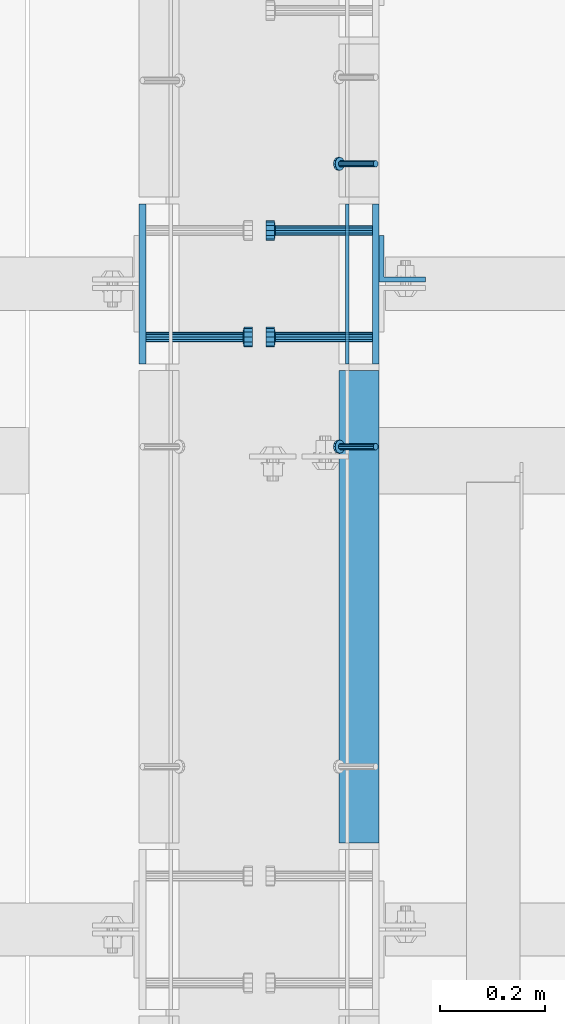
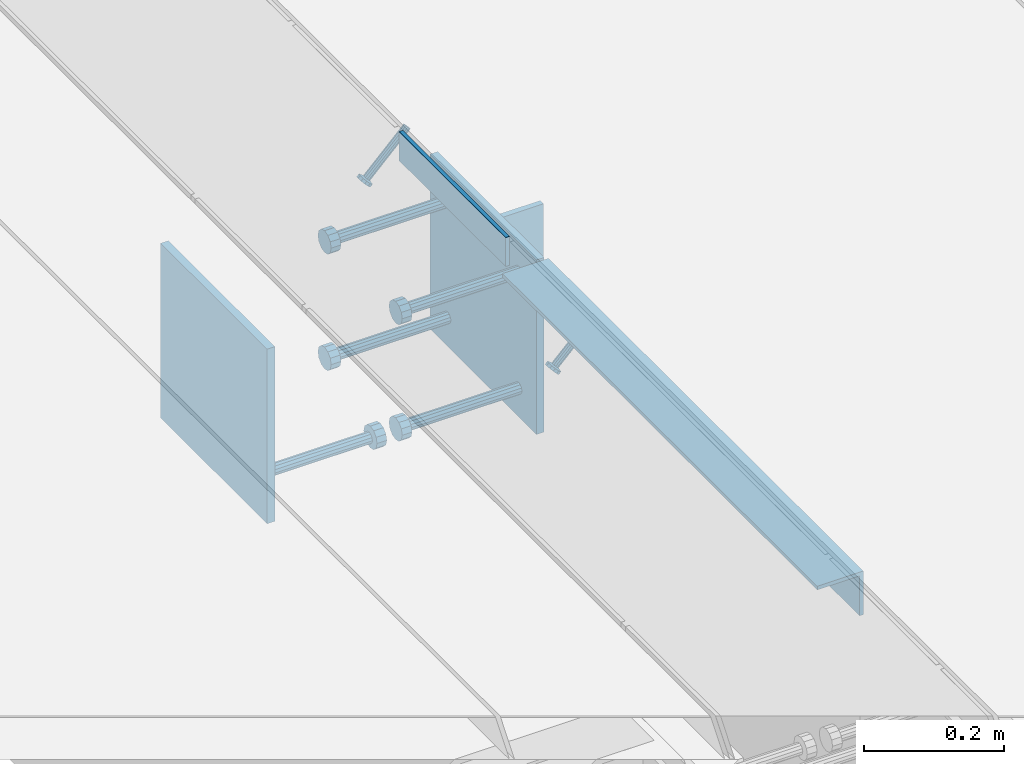
# One storey, part 2148 of 3843: 10 beams, 2 members, 5 elements without a shape of their own.
"""IFC2X3 building model written with IfcOpenShell, lengths in millimetres."""

from ifc_helpers import new_model, si_unit, frame, origin_with_axes, place, context, subcontext, project, spatial, faceted_brep, material, type_object, element, aggregate, save


model = new_model("IFC2X3")

# Units and contexts
model_context = context("Model", 3, precision=1e-05, world=origin_with_axes())
body_context = subcontext(model_context, "Body", "Model", "MODEL_VIEW")
ifc_project = project(units=[si_unit("LENGTHUNIT", "METRE", prefix="MILLI"), si_unit("AREAUNIT", "SQUARE_METRE"), si_unit("VOLUMEUNIT", "CUBIC_METRE"), si_unit("MASSUNIT", "GRAM", prefix="KILO"), si_unit("TIMEUNIT", "SECOND"), si_unit("PLANEANGLEUNIT", "RADIAN"), si_unit("SOLIDANGLEUNIT", "STERADIAN"), si_unit("THERMODYNAMICTEMPERATUREUNIT", "DEGREE_CELSIUS"), si_unit("LUMINOUSINTENSITYUNIT", "LUMEN")], contexts=[model_context])

# Site, building, storey
site_placement = place(None, origin_with_axes())
site = spatial("IfcSite", under=ifc_project, at=site_placement, CompositionType="ELEMENT")
building_placement = place(site_placement, origin_with_axes())
building = spatial("IfcBuilding", under=site, at=building_placement, Name="Undefined", CompositionType="ELEMENT")
storey_placement = place(building_placement, origin_with_axes())
storey = spatial("IfcBuildingStorey", under=building, at=storey_placement, Name="Undefined", CompositionType="ELEMENT", Elevation=0.0)

# Assembly, beam
assembly_1_placement = place(storey_placement, origin_with_axes())
assembly_1 = element("IfcElementAssembly", 1, at=assembly_1_placement, inside=storey, Name="EMBED PLATE", AssemblyPlace="NOTDEFINED", PredefinedType="RIGID_FRAME")
ifc_material_1 = material(Name="STEEL/A36")
beam_type_1 = type_object("IfcBeamType", PredefinedType="NOTDEFINED")
beam_1_placement = place(assembly_1_placement, frame((62728.4750030518, 17306.925, 30454.6), z_axis=(0.0, 0.0, 1.0), x_axis=(0.0, 1.0, 0.0)))
beam_1 = element("IfcBeam", 2, at=beam_1_placement, type_object=beam_type_1, material=ifc_material_1, Name="PLATE", context=body_context, shape_type="Brep", body=[
    faceted_brep([(0.0, 3.17499999999927, -25.4000000000015), (0.0, 3.17499999999927, 25.4000000000015), (304.800000000003, 3.17500000000291, 25.4000000000015), (304.800000000003, 3.17500000000291, -25.4000000000015), (0.0, -3.17499999999927, 25.4000000000015), (304.800000000003, -3.17500000000291, 25.4000000000015), (0.0, -3.17499999999927, -25.4000000000015), (304.800000000003, -3.17500000000291, -25.4000000000015)], [[[0, 1, 2, 3]], [[1, 4, 5, 2]], [[4, 6, 7, 5]], [[6, 0, 3, 7]], [[5, 7, 3, 2]], [[6, 4, 1, 0]]]),
])

# Assembly, member
assembly_2_placement = place(storey_placement, origin_with_axes())
assembly_2 = element("IfcElementAssembly", 3, at=assembly_2_placement, inside=storey, Name="ANGLE", AssemblyPlace="NOTDEFINED", PredefinedType="RIGID_FRAME")
ifc_material_2 = material(Name="STEEL/A108")
member_type = type_object("IfcMemberType", PredefinedType="NOTDEFINED")
member_1_placement = place(assembly_2_placement, frame((62782.4499976766, 17687.9250728612, 30422.8500045777), z_axis=(0.0, -1.0, 0.0), x_axis=(-0.707106781186548, 0.0, -0.707106781186548)))
member_1 = element("IfcMember", 4, at=member_1_placement, type_object=member_type, material=ifc_material_2, Name="HEADED STUD ANCHOR", context=body_context, shape_type="Brep", body=[
    faceted_brep([(7.27595761418343e-12, -3.18000006675175, 5.5), (0.0, -5.49999999998363, 3.1800000667572), (94.4879985803855, -5.50000000011278, 3.1800000667572), (94.4879985803782, -3.18000006687362, 5.5), (0.0, -6.3499999046162, 0.0), (94.4879985803855, -6.34999990474535, 0.0), (0.0, -5.49999999998363, -3.1800000667572), (94.4879985803855, -5.50000000011278, -3.1800000667572), (7.27595761418343e-12, -3.18000006675175, -5.5), (94.4879985803782, -3.18000006687362, -5.5), (7.27595761418343e-12, -1.81898940354586e-12, -6.34999990463257), (94.4879985803782, -1.20053300634027e-10, -6.34999990463257), (0.0, 3.18000006675175, -5.5), (94.4879985803709, 3.18000006663351, -5.5), (7.27595761418343e-12, 5.49999999998363, -3.1800000667572), (94.4879985803709, 5.49999999987267, -3.1800000667572), (7.27595761418343e-12, 6.3499999046162, 0.0), (94.4879985803673, 6.34999990450706, 0.0), (7.27595761418343e-12, 5.49999999998363, 3.1800000667572), (94.4879985803709, 5.49999999987267, 3.1800000667572), (0.0, 3.18000006675175, 5.5), (94.4879985803709, 3.18000006663351, 5.5), (7.27595761418343e-12, -1.81898940354586e-12, 6.34999990463257), (94.4879985803782, -1.20053300634027e-10, 6.34999990463257), (96.5199985498621, -10.9899997712273, 6.34999990463257), (96.5199985498548, -6.34000015270249, 10.9899997711182), (96.5199985498621, -12.6999998093743, 0.0), (96.5199985498621, -10.9899997712273, -6.34999990463257), (96.5199985498548, -6.34000015270249, -10.9899997711182), (96.5199985498475, -1.21872290037572e-10, -12.6899995803833), (96.5199985498402, 6.34000015245874, -10.9899997711182), (96.519998549833, 10.9899997709817, -6.34999990463257), (96.519998549833, 12.6999998091305, 0.0), (96.519998549833, 10.9899997709817, 6.34999990463257), (96.5199985498402, 6.34000015245874, 10.9899997711182), (96.5199985498475, -1.21872290037572e-10, 12.6899995803833), (101.599998473539, -10.9899997712328, 6.34999990463257), (101.599998473532, -6.34000015270976, 10.9899997711182), (101.599998473539, -12.6999998093797, 0.0), (101.599998473539, -10.9899997712328, -6.34999990463257), (101.599998473532, -6.34000015270976, -10.9899997711182), (101.599998473524, -1.29148247651756e-10, -12.6899995803833), (101.599998473517, 6.34000015245329, -10.9899997711182), (101.59999847351, 10.9899997709763, -6.34999990463257), (101.599998473503, 12.6999998091196, 0.0), (101.59999847351, 10.9899997709763, 6.34999990463257), (101.599998473517, 6.34000015245329, 10.9899997711182), (101.599998473524, -1.29148247651756e-10, 12.6899995803833)], [[[0, 1, 2, 3]], [[1, 4, 5, 2]], [[4, 6, 7, 5]], [[6, 8, 9, 7]], [[8, 10, 11, 9]], [[10, 12, 13, 11]], [[12, 14, 15, 13]], [[14, 16, 17, 15]], [[16, 18, 19, 17]], [[18, 20, 21, 19]], [[20, 22, 23, 21]], [[22, 0, 3, 23]], [[22, 20, 18, 16, 14, 12, 10, 8, 6, 4, 1, 0]], [[3, 2, 24, 25]], [[2, 5, 26, 24]], [[5, 7, 27, 26]], [[7, 9, 28, 27]], [[9, 11, 29, 28]], [[11, 13, 30, 29]], [[13, 15, 31, 30]], [[15, 17, 32, 31]], [[17, 19, 33, 32]], [[19, 21, 34, 33]], [[21, 23, 35, 34]], [[23, 3, 25, 35]], [[25, 24, 36, 37]], [[24, 26, 38, 36]], [[26, 27, 39, 38]], [[27, 28, 40, 39]], [[28, 29, 41, 40]], [[29, 30, 42, 41]], [[30, 31, 43, 42]], [[31, 32, 44, 43]], [[32, 33, 45, 44]], [[33, 34, 46, 45]], [[34, 35, 47, 46]], [[35, 25, 37, 47]], [[38, 39, 40, 41, 42, 43, 44, 45, 46, 47, 37, 36]]]),
])
aggregate(assembly_2, [member_1])

assembly_3_placement = place(storey_placement, origin_with_axes())
assembly_3 = element("IfcElementAssembly", 5, at=assembly_3_placement, inside=storey, Name="ANGLE", AssemblyPlace="NOTDEFINED", PredefinedType="RIGID_FRAME")
member_2_placement = place(assembly_3_placement, frame((62782.449995556, 17148.9684967422, 30422.8500045777), z_axis=(0.0, -1.0, 0.0), x_axis=(-0.707106781186548, 0.0, -0.707106781186548)))
member_2 = element("IfcMember", 6, at=member_2_placement, type_object=member_type, material=ifc_material_2, Name="HEADED STUD ANCHOR", context=body_context, shape_type="Brep", body=[
    faceted_brep([(7.27595761418343e-12, -3.18000006675175, 5.5), (0.0, -5.49999999998363, 3.1800000667572), (94.4879985803855, -5.50000000011278, 3.1800000667572), (94.4879985803782, -3.18000006687362, 5.5), (0.0, -6.3499999046162, 0.0), (94.4879985803855, -6.34999990474535, 0.0), (0.0, -5.49999999998363, -3.1800000667572), (94.4879985803855, -5.50000000011278, -3.1800000667572), (7.27595761418343e-12, -3.18000006675175, -5.5), (94.4879985803782, -3.18000006687362, -5.5), (7.27595761418343e-12, -1.81898940354586e-12, -6.34999990463257), (94.4879985803782, -1.20053300634027e-10, -6.34999990463257), (0.0, 3.18000006675175, -5.5), (94.4879985803709, 3.18000006663351, -5.5), (7.27595761418343e-12, 5.49999999998363, -3.1800000667572), (94.4879985803709, 5.49999999987267, -3.1800000667572), (7.27595761418343e-12, 6.3499999046162, 0.0), (94.4879985803673, 6.34999990450706, 0.0), (7.27595761418343e-12, 5.49999999998363, 3.1800000667572), (94.4879985803709, 5.49999999987267, 3.1800000667572), (0.0, 3.18000006675175, 5.5), (94.4879985803709, 3.18000006663351, 5.5), (7.27595761418343e-12, -1.81898940354586e-12, 6.34999990463257), (94.4879985803782, -1.20053300634027e-10, 6.34999990463257), (96.5199985498621, -10.9899997712273, 6.34999990463257), (96.5199985498548, -6.34000015270249, 10.9899997711182), (96.5199985498621, -12.6999998093743, 0.0), (96.5199985498621, -10.9899997712273, -6.34999990463257), (96.5199985498548, -6.34000015270249, -10.9899997711182), (96.5199985498475, -1.21872290037572e-10, -12.6899995803833), (96.5199985498402, 6.34000015245874, -10.9899997711182), (96.519998549833, 10.9899997709817, -6.34999990463257), (96.519998549833, 12.6999998091305, 0.0), (96.519998549833, 10.9899997709817, 6.34999990463257), (96.5199985498402, 6.34000015245874, 10.9899997711182), (96.5199985498475, -1.21872290037572e-10, 12.6899995803833), (101.599998473539, -10.9899997712328, 6.34999990463257), (101.599998473532, -6.34000015270976, 10.9899997711182), (101.599998473539, -12.6999998093797, 0.0), (101.599998473539, -10.9899997712328, -6.34999990463257), (101.599998473532, -6.34000015270976, -10.9899997711182), (101.599998473524, -1.29148247651756e-10, -12.6899995803833), (101.599998473517, 6.34000015245329, -10.9899997711182), (101.59999847351, 10.9899997709763, -6.34999990463257), (101.599998473503, 12.6999998091196, 0.0), (101.59999847351, 10.9899997709763, 6.34999990463257), (101.599998473517, 6.34000015245329, 10.9899997711182), (101.599998473524, -1.29148247651756e-10, 12.6899995803833)], [[[0, 1, 2, 3]], [[1, 4, 5, 2]], [[4, 6, 7, 5]], [[6, 8, 9, 7]], [[8, 10, 11, 9]], [[10, 12, 13, 11]], [[12, 14, 15, 13]], [[14, 16, 17, 15]], [[16, 18, 19, 17]], [[18, 20, 21, 19]], [[20, 22, 23, 21]], [[22, 0, 3, 23]], [[22, 20, 18, 16, 14, 12, 10, 8, 6, 4, 1, 0]], [[3, 2, 24, 25]], [[2, 5, 26, 24]], [[5, 7, 27, 26]], [[7, 9, 28, 27]], [[9, 11, 29, 28]], [[11, 13, 30, 29]], [[13, 15, 31, 30]], [[15, 17, 32, 31]], [[17, 19, 33, 32]], [[19, 21, 34, 33]], [[21, 23, 35, 34]], [[23, 3, 25, 35]], [[25, 24, 36, 37]], [[24, 26, 38, 36]], [[26, 27, 39, 38]], [[27, 28, 40, 39]], [[28, 29, 41, 40]], [[29, 30, 42, 41]], [[30, 31, 43, 42]], [[31, 32, 44, 43]], [[32, 33, 45, 44]], [[33, 34, 46, 45]], [[34, 35, 47, 46]], [[35, 25, 37, 47]], [[38, 39, 40, 41, 42, 43, 44, 45, 46, 47, 37, 36]]]),
])

# Assembly, beam
assembly_4_placement = place(storey_placement, origin_with_axes())
assembly_4 = element("IfcElementAssembly", 7, at=assembly_4_placement, inside=storey, Name="EMBED PLATE", AssemblyPlace="NOTDEFINED", PredefinedType="RIGID_FRAME")
beam_type_2 = type_object("IfcBeamType", PredefinedType="NOTDEFINED")
beam_2_placement = place(assembly_4_placement, frame((62337.9499969482, 17459.325, 30422.85), z_axis=(0.0, -1.0, 0.0), x_axis=(0.0, 0.0, -1.0)))
beam_2 = element("IfcBeam", 8, at=beam_2_placement, type_object=beam_type_2, material=ifc_material_1, Name="EMBED PLATE", context=body_context, shape_type="Brep", body=[
    faceted_brep([(-1.0550138540566e-10, 6.34999999999854, -152.400000000664), (1.0550138540566e-10, 6.34999999999854, 152.400000000656), (304.799999999999, 6.34999999999854, 152.400000000001), (304.799999999999, 6.34999999999854, -152.400000000001), (1.0550138540566e-10, -6.34999999999854, 152.400000000656), (304.799999999999, -6.34999999999854, 152.400000000001), (-1.0550138540566e-10, -6.34999999999854, -152.400000000664), (304.799999999999, -6.34999999999854, -152.400000000001)], [[[0, 1, 2, 3]], [[1, 4, 5, 2]], [[4, 6, 7, 5]], [[6, 0, 3, 7]], [[5, 7, 3, 2]], [[6, 4, 1, 0]]]),
])

# Beam
beam_3_placement = place(assembly_1_placement, frame((62782.4500030517, 17459.325, 30422.85), z_axis=(0.0, 1.0, 0.0), x_axis=(0.0, 0.0, -1.0)))
beam_3 = element("IfcBeam", 9, at=beam_3_placement, type_object=beam_type_2, material=ifc_material_1, Name="EMBED PLATE", context=body_context, shape_type="Brep", body=[
    faceted_brep([(-1.0550138540566e-10, 6.34999999999854, -152.400000000664), (1.0550138540566e-10, 6.34999999999854, 152.400000000656), (304.799999999999, 6.34999999999854, 152.400000000001), (304.799999999999, 6.34999999999854, -152.400000000001), (1.0550138540566e-10, -6.34999999999854, 152.400000000656), (304.799999999999, -6.34999999999854, 152.400000000001), (-1.0550138540566e-10, -6.34999999999854, -152.400000000664), (304.799999999999, -6.34999999999854, -152.400000000001)], [[[0, 1, 2, 3]], [[1, 4, 5, 2]], [[4, 6, 7, 5]], [[6, 0, 3, 7]], [[5, 7, 3, 2]], [[6, 4, 1, 0]]]),
])

beam_type_3 = type_object("IfcBeamType", Name="L3X3X1/4", PredefinedType="NOTDEFINED")
beam_4_placement = place(assembly_3_placement, frame((62750.6999946842, 16394.1125002286, 30391.1000045777), z_axis=(0.0, 0.0, -1.0), x_axis=(0.0, 1.0, 0.0)))
beam_4 = element("IfcBeam", 10, at=beam_4_placement, type_object=beam_type_3, material=ifc_material_1, Name="ANGLE", ObjectType="L3X3X1/4", context=body_context, shape_type="Brep", body=[
    faceted_brep([(0.0, 38.0999999999985, -38.0999999999985), (0.0, 38.0999999999985, 38.0999999999985), (900.112000000037, 38.1000000023996, 38.0999999999985), (900.112000000037, 38.1000000023996, -38.0999999999985), (0.0, 31.75, 38.0999999999985), (900.11200000003, 31.7500000023938, 38.0999999999985), (0.0, 31.75, -31.75), (900.11200000003, 31.7500000023938, -31.75), (0.0, -38.0999999999985, -31.75), (900.111999999965, -38.0999999976048, -31.75), (0.0, -38.0999999999985, -38.0999999999985), (900.111999999965, -38.0999999976048, -38.0999999999985)], [[[0, 1, 2, 3]], [[1, 4, 5, 2]], [[4, 6, 7, 5]], [[6, 8, 9, 7]], [[8, 10, 11, 9]], [[10, 0, 3, 11]], [[5, 7, 9, 11, 3, 2]], [[10, 8, 6, 4, 1, 0]]]),
])

aggregate(assembly_3, [member_2, beam_4])

# Assembly, beam
assembly_5_placement = place(storey_placement, origin_with_axes())
assembly_5 = element("IfcElementAssembly", 11, at=assembly_5_placement, inside=storey, Name="BEAM", AssemblyPlace="NOTDEFINED", PredefinedType="RIGID_FRAME")
beam_type_4 = type_object("IfcBeamType", Name="L3-1/2X3-1/2X3/8", PredefinedType="NOTDEFINED")
beam_5_placement = place(assembly_5_placement, frame((62833.2500030518, 17506.95, 30391.1), z_axis=(0.0, 1.0, 0.0), x_axis=(0.0, 0.0, -1.0)))
beam_5 = element("IfcBeam", 12, at=beam_5_placement, type_object=beam_type_4, material=ifc_material_1, Name="ANGLE", ObjectType="L3-1/2X3-1/2X3/8", context=body_context, shape_type="Brep", body=[
    faceted_brep([(-3.63797880709171e-12, 44.4499999999971, -44.4500000000007), (-3.63797880709171e-12, 44.4499999999971, 44.4500000000007), (228.600000000006, 44.4499999999971, 44.4500000000007), (228.600000000006, 44.4499999999971, -44.4500000000007), (0.0, 34.9250000000029, 44.4500000000007), (228.600000000006, 34.9250000000029, 44.4500000000007), (0.0, 34.9250000000029, -34.9250000000029), (228.600000000006, 34.9250000000029, -34.9249999999993), (0.0, -44.4499999999971, -34.9249999999993), (228.600000000006, -44.4499999999971, -34.9249999999993), (3.63797880709171e-12, -44.4499999999971, -44.4500000000007), (228.600000000006, -44.4499999999971, -44.4500000000007)], [[[0, 1, 2, 3]], [[1, 4, 5, 2]], [[4, 6, 7, 5]], [[6, 8, 9, 7]], [[8, 10, 11, 9]], [[10, 0, 3, 11]], [[5, 7, 9, 11, 3, 2]], [[10, 8, 6, 4, 1, 0]]]),
])
aggregate(assembly_5, [beam_5])

# Beam
beam_type_5 = type_object("IfcBeamType", PredefinedType="NOTDEFINED")
beam_6_placement = place(assembly_4_placement, frame((62344.2999969482, 17357.725, 30168.85), z_axis=(0.0, 1.0, 0.0), x_axis=(1.0, 0.0, 0.0)))
beam_6 = element("IfcBeam", 13, at=beam_6_placement, type_object=beam_type_5, material=ifc_material_2, Name="HEADED STUD ANCHOR", context=body_context, shape_type="Brep", body=[
    faceted_brep([(0.0, -9.52000045776367, 0.0), (0.0, -8.25, -4.76000022888184), (184.912000000004, -8.25, -4.76000022888184), (184.912000000004, -9.52000045776367, 0.0), (0.0, -4.76000022888184, -8.25), (184.912000000004, -4.76000022888184, -8.25), (0.0, 0.0, -9.52000045776367), (184.912000000004, 0.0, -9.52000045776367), (0.0, 4.76000022888184, -8.25), (184.912000000004, 4.76000022888184, -8.25), (0.0, 8.25, -4.76000022888184), (184.912000000004, 8.25, -4.76000022888184), (0.0, 9.52000045776367, 0.0), (184.912000000004, 9.52000045776367, 0.0), (0.0, 8.25, 4.76000022888184), (184.912000000004, 8.25, 4.76000022888184), (0.0, 4.76000022888184, 8.25), (184.912000000004, 4.76000022888184, 8.25), (0.0, 0.0, 9.52000045776367), (184.912000000004, 0.0, 9.52000045776367), (0.0, -4.76000022888184, 8.25), (184.912000000004, -4.76000022888184, 8.25), (0.0, -8.25, 4.76000022888184), (184.912000000004, -8.25, 4.76000022888184), (186.944000000003, -16.5, -9.52000045776367), (186.944000000003, -19.0499992370605, 0.0), (186.944000000003, -9.52000045776367, -16.5), (186.944000000003, 0.0, -19.0499992370605), (186.944000000003, 9.52000045776367, -16.5), (186.944000000003, 16.5, -9.52000045776367), (186.944000000003, 19.0499992370605, 0.0), (186.944000000003, 16.5, 9.52000045776367), (186.944000000003, 9.52000045776367, 16.5), (186.944000000003, 0.0, 19.0499992370605), (186.944000000003, -9.52000045776367, 16.5), (186.944000000003, -16.5, 9.52000045776367), (203.199999999997, -16.5, -9.52000045776367), (203.199999999997, -19.0499992370605, 0.0), (203.199999999997, -9.52000045776367, -16.5), (203.199999999997, 0.0, -19.0499992370605), (203.199999999997, 9.52000045776367, -16.5), (203.199999999997, 16.5, -9.52000045776367), (203.199999999997, 19.0499992370605, 0.0), (203.199999999997, 16.5, 9.52000045776367), (203.199999999997, 9.52000045776367, 16.5), (203.199999999997, 0.0, 19.0499992370605), (203.199999999997, -9.52000045776367, 16.5), (203.199999999997, -16.5, 9.52000045776367)], [[[0, 1, 2, 3]], [[1, 4, 5, 2]], [[4, 6, 7, 5]], [[6, 8, 9, 7]], [[8, 10, 11, 9]], [[10, 12, 13, 11]], [[12, 14, 15, 13]], [[14, 16, 17, 15]], [[16, 18, 19, 17]], [[18, 20, 21, 19]], [[20, 22, 23, 21]], [[22, 0, 3, 23]], [[22, 20, 18, 16, 14, 12, 10, 8, 6, 4, 1, 0]], [[3, 2, 24, 25]], [[2, 5, 26, 24]], [[5, 7, 27, 26]], [[7, 9, 28, 27]], [[9, 11, 29, 28]], [[11, 13, 30, 29]], [[13, 15, 31, 30]], [[15, 17, 32, 31]], [[17, 19, 33, 32]], [[19, 21, 34, 33]], [[21, 23, 35, 34]], [[23, 3, 25, 35]], [[25, 24, 36, 37]], [[24, 26, 38, 36]], [[26, 27, 39, 38]], [[27, 28, 40, 39]], [[28, 29, 41, 40]], [[29, 30, 42, 41]], [[30, 31, 43, 42]], [[31, 32, 44, 43]], [[32, 33, 45, 44]], [[33, 34, 46, 45]], [[34, 35, 47, 46]], [[35, 25, 37, 47]], [[38, 39, 40, 41, 42, 43, 44, 45, 46, 47, 37, 36]]]),
])

aggregate(assembly_4, [beam_6, beam_2])

beam_7_placement = place(assembly_1_placement, frame((62776.1000030517, 17357.725, 30372.05), z_axis=(0.0, -1.0, 0.0), x_axis=(-1.0, 0.0, 0.0)))
beam_7 = element("IfcBeam", 14, at=beam_7_placement, type_object=beam_type_5, material=ifc_material_2, Name="HEADED STUD ANCHOR", context=body_context, shape_type="Brep", body=[
    faceted_brep([(0.0, -9.52000045776367, 0.0), (0.0, -8.25, -4.76000022888184), (184.912000000004, -8.25, -4.76000022888184), (184.912000000004, -9.52000045776367, 0.0), (0.0, -4.76000022888184, -8.25), (184.912000000004, -4.76000022888184, -8.25), (0.0, 0.0, -9.52000045776367), (184.912000000004, 0.0, -9.52000045776367), (0.0, 4.76000022888184, -8.25), (184.912000000004, 4.76000022888184, -8.25), (0.0, 8.25, -4.76000022888184), (184.912000000004, 8.25, -4.76000022888184), (0.0, 9.52000045776367, 0.0), (184.912000000004, 9.52000045776367, 0.0), (0.0, 8.25, 4.76000022888184), (184.912000000004, 8.25, 4.76000022888184), (0.0, 4.76000022888184, 8.25), (184.912000000004, 4.76000022888184, 8.25), (0.0, 0.0, 9.52000045776367), (184.912000000004, 0.0, 9.52000045776367), (0.0, -4.76000022888184, 8.25), (184.912000000004, -4.76000022888184, 8.25), (0.0, -8.25, 4.76000022888184), (184.912000000004, -8.25, 4.76000022888184), (186.944000000003, -16.5, -9.52000045776367), (186.944000000003, -19.0499992370605, 0.0), (186.944000000003, -9.52000045776367, -16.5), (186.944000000003, 0.0, -19.0499992370605), (186.944000000003, 9.52000045776367, -16.5), (186.944000000003, 16.5, -9.52000045776367), (186.944000000003, 19.0499992370605, 0.0), (186.944000000003, 16.5, 9.52000045776367), (186.944000000003, 9.52000045776367, 16.5), (186.944000000003, 0.0, 19.0499992370605), (186.944000000003, -9.52000045776367, 16.5), (186.944000000003, -16.5, 9.52000045776367), (203.199999999997, -16.5, -9.52000045776367), (203.199999999997, -19.0499992370605, 0.0), (203.199999999997, -9.52000045776367, -16.5), (203.199999999997, 0.0, -19.0499992370605), (203.199999999997, 9.52000045776367, -16.5), (203.199999999997, 16.5, -9.52000045776367), (203.199999999997, 19.0499992370605, 0.0), (203.199999999997, 16.5, 9.52000045776367), (203.199999999997, 9.52000045776367, 16.5), (203.199999999997, 0.0, 19.0499992370605), (203.199999999997, -9.52000045776367, 16.5), (203.199999999997, -16.5, 9.52000045776367)], [[[0, 1, 2, 3]], [[1, 4, 5, 2]], [[4, 6, 7, 5]], [[6, 8, 9, 7]], [[8, 10, 11, 9]], [[10, 12, 13, 11]], [[12, 14, 15, 13]], [[14, 16, 17, 15]], [[16, 18, 19, 17]], [[18, 20, 21, 19]], [[20, 22, 23, 21]], [[22, 0, 3, 23]], [[22, 20, 18, 16, 14, 12, 10, 8, 6, 4, 1, 0]], [[3, 2, 24, 25]], [[2, 5, 26, 24]], [[5, 7, 27, 26]], [[7, 9, 28, 27]], [[9, 11, 29, 28]], [[11, 13, 30, 29]], [[13, 15, 31, 30]], [[15, 17, 32, 31]], [[17, 19, 33, 32]], [[19, 21, 34, 33]], [[21, 23, 35, 34]], [[23, 3, 25, 35]], [[25, 24, 36, 37]], [[24, 26, 38, 36]], [[26, 27, 39, 38]], [[27, 28, 40, 39]], [[28, 29, 41, 40]], [[29, 30, 42, 41]], [[30, 31, 43, 42]], [[31, 32, 44, 43]], [[32, 33, 45, 44]], [[33, 34, 46, 45]], [[34, 35, 47, 46]], [[35, 25, 37, 47]], [[38, 39, 40, 41, 42, 43, 44, 45, 46, 47, 37, 36]]]),
])

beam_8_placement = place(assembly_1_placement, frame((62776.1000030517, 17357.725, 30168.85), z_axis=(0.0, -1.0, 0.0), x_axis=(-1.0, 0.0, 0.0)))
beam_8 = element("IfcBeam", 15, at=beam_8_placement, type_object=beam_type_5, material=ifc_material_2, Name="HEADED STUD ANCHOR", context=body_context, shape_type="Brep", body=[
    faceted_brep([(0.0, -9.52000045776367, 0.0), (0.0, -8.25, -4.76000022888184), (184.912000000004, -8.25, -4.76000022888184), (184.912000000004, -9.52000045776367, 0.0), (0.0, -4.76000022888184, -8.25), (184.912000000004, -4.76000022888184, -8.25), (0.0, 0.0, -9.52000045776367), (184.912000000004, 0.0, -9.52000045776367), (0.0, 4.76000022888184, -8.25), (184.912000000004, 4.76000022888184, -8.25), (0.0, 8.25, -4.76000022888184), (184.912000000004, 8.25, -4.76000022888184), (0.0, 9.52000045776367, 0.0), (184.912000000004, 9.52000045776367, 0.0), (0.0, 8.25, 4.76000022888184), (184.912000000004, 8.25, 4.76000022888184), (0.0, 4.76000022888184, 8.25), (184.912000000004, 4.76000022888184, 8.25), (0.0, 0.0, 9.52000045776367), (184.912000000004, 0.0, 9.52000045776367), (0.0, -4.76000022888184, 8.25), (184.912000000004, -4.76000022888184, 8.25), (0.0, -8.25, 4.76000022888184), (184.912000000004, -8.25, 4.76000022888184), (186.944000000003, -16.5, -9.52000045776367), (186.944000000003, -19.0499992370605, 0.0), (186.944000000003, -9.52000045776367, -16.5), (186.944000000003, 0.0, -19.0499992370605), (186.944000000003, 9.52000045776367, -16.5), (186.944000000003, 16.5, -9.52000045776367), (186.944000000003, 19.0499992370605, 0.0), (186.944000000003, 16.5, 9.52000045776367), (186.944000000003, 9.52000045776367, 16.5), (186.944000000003, 0.0, 19.0499992370605), (186.944000000003, -9.52000045776367, 16.5), (186.944000000003, -16.5, 9.52000045776367), (203.199999999997, -16.5, -9.52000045776367), (203.199999999997, -19.0499992370605, 0.0), (203.199999999997, -9.52000045776367, -16.5), (203.199999999997, 0.0, -19.0499992370605), (203.199999999997, 9.52000045776367, -16.5), (203.199999999997, 16.5, -9.52000045776367), (203.199999999997, 19.0499992370605, 0.0), (203.199999999997, 16.5, 9.52000045776367), (203.199999999997, 9.52000045776367, 16.5), (203.199999999997, 0.0, 19.0499992370605), (203.199999999997, -9.52000045776367, 16.5), (203.199999999997, -16.5, 9.52000045776367)], [[[0, 1, 2, 3]], [[1, 4, 5, 2]], [[4, 6, 7, 5]], [[6, 8, 9, 7]], [[8, 10, 11, 9]], [[10, 12, 13, 11]], [[12, 14, 15, 13]], [[14, 16, 17, 15]], [[16, 18, 19, 17]], [[18, 20, 21, 19]], [[20, 22, 23, 21]], [[22, 0, 3, 23]], [[22, 20, 18, 16, 14, 12, 10, 8, 6, 4, 1, 0]], [[3, 2, 24, 25]], [[2, 5, 26, 24]], [[5, 7, 27, 26]], [[7, 9, 28, 27]], [[9, 11, 29, 28]], [[11, 13, 30, 29]], [[13, 15, 31, 30]], [[15, 17, 32, 31]], [[17, 19, 33, 32]], [[19, 21, 34, 33]], [[21, 23, 35, 34]], [[23, 3, 25, 35]], [[25, 24, 36, 37]], [[24, 26, 38, 36]], [[26, 27, 39, 38]], [[27, 28, 40, 39]], [[28, 29, 41, 40]], [[29, 30, 42, 41]], [[30, 31, 43, 42]], [[31, 32, 44, 43]], [[32, 33, 45, 44]], [[33, 34, 46, 45]], [[34, 35, 47, 46]], [[35, 25, 37, 47]], [[38, 39, 40, 41, 42, 43, 44, 45, 46, 47, 37, 36]]]),
])

beam_9_placement = place(assembly_1_placement, frame((62776.1000030517, 17560.925, 30372.05), z_axis=(0.0, -1.0, 0.0), x_axis=(-1.0, 0.0, 0.0)))
beam_9 = element("IfcBeam", 16, at=beam_9_placement, type_object=beam_type_5, material=ifc_material_1, Name="PLATE", context=body_context, shape_type="Brep", body=[
    faceted_brep([(0.0, -9.52000045776367, 0.0), (0.0, -8.25, -4.76000022888184), (184.912000000004, -8.25, -4.76000022888184), (184.912000000004, -9.52000045776367, 0.0), (0.0, -4.76000022888184, -8.25), (184.912000000004, -4.76000022888184, -8.25), (0.0, 0.0, -9.52000045776367), (184.912000000004, 0.0, -9.52000045776367), (0.0, 4.76000022888184, -8.25), (184.912000000004, 4.76000022888184, -8.25), (0.0, 8.25, -4.76000022888184), (184.912000000004, 8.25, -4.76000022888184), (0.0, 9.52000045776367, 0.0), (184.912000000004, 9.52000045776367, 0.0), (0.0, 8.25, 4.76000022888184), (184.912000000004, 8.25, 4.76000022888184), (0.0, 4.76000022888184, 8.25), (184.912000000004, 4.76000022888184, 8.25), (0.0, 0.0, 9.52000045776367), (184.912000000004, 0.0, 9.52000045776367), (0.0, -4.76000022888184, 8.25), (184.912000000004, -4.76000022888184, 8.25), (0.0, -8.25, 4.76000022888184), (184.912000000004, -8.25, 4.76000022888184), (186.944000000003, -16.5, -9.52000045776367), (186.944000000003, -19.0499992370605, 0.0), (186.944000000003, -9.52000045776367, -16.5), (186.944000000003, 0.0, -19.0499992370605), (186.944000000003, 9.52000045776367, -16.5), (186.944000000003, 16.5, -9.52000045776367), (186.944000000003, 19.0499992370605, 0.0), (186.944000000003, 16.5, 9.52000045776367), (186.944000000003, 9.52000045776367, 16.5), (186.944000000003, 0.0, 19.0499992370605), (186.944000000003, -9.52000045776367, 16.5), (186.944000000003, -16.5, 9.52000045776367), (203.199999999997, -16.5, -9.52000045776367), (203.199999999997, -19.0499992370605, 0.0), (203.199999999997, -9.52000045776367, -16.5), (203.199999999997, 0.0, -19.0499992370605), (203.199999999997, 9.52000045776367, -16.5), (203.199999999997, 16.5, -9.52000045776367), (203.199999999997, 19.0499992370605, 0.0), (203.199999999997, 16.5, 9.52000045776367), (203.199999999997, 9.52000045776367, 16.5), (203.199999999997, 0.0, 19.0499992370605), (203.199999999997, -9.52000045776367, 16.5), (203.199999999997, -16.5, 9.52000045776367)], [[[0, 1, 2, 3]], [[1, 4, 5, 2]], [[4, 6, 7, 5]], [[6, 8, 9, 7]], [[8, 10, 11, 9]], [[10, 12, 13, 11]], [[12, 14, 15, 13]], [[14, 16, 17, 15]], [[16, 18, 19, 17]], [[18, 20, 21, 19]], [[20, 22, 23, 21]], [[22, 0, 3, 23]], [[22, 20, 18, 16, 14, 12, 10, 8, 6, 4, 1, 0]], [[3, 2, 24, 25]], [[2, 5, 26, 24]], [[5, 7, 27, 26]], [[7, 9, 28, 27]], [[9, 11, 29, 28]], [[11, 13, 30, 29]], [[13, 15, 31, 30]], [[15, 17, 32, 31]], [[17, 19, 33, 32]], [[19, 21, 34, 33]], [[21, 23, 35, 34]], [[23, 3, 25, 35]], [[25, 24, 36, 37]], [[24, 26, 38, 36]], [[26, 27, 39, 38]], [[27, 28, 40, 39]], [[28, 29, 41, 40]], [[29, 30, 42, 41]], [[30, 31, 43, 42]], [[31, 32, 44, 43]], [[32, 33, 45, 44]], [[33, 34, 46, 45]], [[34, 35, 47, 46]], [[35, 25, 37, 47]], [[38, 39, 40, 41, 42, 43, 44, 45, 46, 47, 37, 36]]]),
])

beam_10_placement = place(assembly_1_placement, frame((62776.1000030517, 17560.925, 30168.85), z_axis=(0.0, -1.0, 0.0), x_axis=(-1.0, 0.0, 0.0)))
beam_10 = element("IfcBeam", 17, at=beam_10_placement, type_object=beam_type_5, material=ifc_material_2, Name="HEADED STUD ANCHOR", context=body_context, shape_type="Brep", body=[
    faceted_brep([(0.0, -9.52000045776367, 0.0), (0.0, -8.25, -4.76000022888184), (184.912000000004, -8.25, -4.76000022888184), (184.912000000004, -9.52000045776367, 0.0), (0.0, -4.76000022888184, -8.25), (184.912000000004, -4.76000022888184, -8.25), (0.0, 0.0, -9.52000045776367), (184.912000000004, 0.0, -9.52000045776367), (0.0, 4.76000022888184, -8.25), (184.912000000004, 4.76000022888184, -8.25), (0.0, 8.25, -4.76000022888184), (184.912000000004, 8.25, -4.76000022888184), (0.0, 9.52000045776367, 0.0), (184.912000000004, 9.52000045776367, 0.0), (0.0, 8.25, 4.76000022888184), (184.912000000004, 8.25, 4.76000022888184), (0.0, 4.76000022888184, 8.25), (184.912000000004, 4.76000022888184, 8.25), (0.0, 0.0, 9.52000045776367), (184.912000000004, 0.0, 9.52000045776367), (0.0, -4.76000022888184, 8.25), (184.912000000004, -4.76000022888184, 8.25), (0.0, -8.25, 4.76000022888184), (184.912000000004, -8.25, 4.76000022888184), (186.944000000003, -16.5, -9.52000045776367), (186.944000000003, -19.0499992370605, 0.0), (186.944000000003, -9.52000045776367, -16.5), (186.944000000003, 0.0, -19.0499992370605), (186.944000000003, 9.52000045776367, -16.5), (186.944000000003, 16.5, -9.52000045776367), (186.944000000003, 19.0499992370605, 0.0), (186.944000000003, 16.5, 9.52000045776367), (186.944000000003, 9.52000045776367, 16.5), (186.944000000003, 0.0, 19.0499992370605), (186.944000000003, -9.52000045776367, 16.5), (186.944000000003, -16.5, 9.52000045776367), (203.199999999997, -16.5, -9.52000045776367), (203.199999999997, -19.0499992370605, 0.0), (203.199999999997, -9.52000045776367, -16.5), (203.199999999997, 0.0, -19.0499992370605), (203.199999999997, 9.52000045776367, -16.5), (203.199999999997, 16.5, -9.52000045776367), (203.199999999997, 19.0499992370605, 0.0), (203.199999999997, 16.5, 9.52000045776367), (203.199999999997, 9.52000045776367, 16.5), (203.199999999997, 0.0, 19.0499992370605), (203.199999999997, -9.52000045776367, 16.5), (203.199999999997, -16.5, 9.52000045776367)], [[[0, 1, 2, 3]], [[1, 4, 5, 2]], [[4, 6, 7, 5]], [[6, 8, 9, 7]], [[8, 10, 11, 9]], [[10, 12, 13, 11]], [[12, 14, 15, 13]], [[14, 16, 17, 15]], [[16, 18, 19, 17]], [[18, 20, 21, 19]], [[20, 22, 23, 21]], [[22, 0, 3, 23]], [[22, 20, 18, 16, 14, 12, 10, 8, 6, 4, 1, 0]], [[3, 2, 24, 25]], [[2, 5, 26, 24]], [[5, 7, 27, 26]], [[7, 9, 28, 27]], [[9, 11, 29, 28]], [[11, 13, 30, 29]], [[13, 15, 31, 30]], [[15, 17, 32, 31]], [[17, 19, 33, 32]], [[19, 21, 34, 33]], [[21, 23, 35, 34]], [[23, 3, 25, 35]], [[25, 24, 36, 37]], [[24, 26, 38, 36]], [[26, 27, 39, 38]], [[27, 28, 40, 39]], [[28, 29, 41, 40]], [[29, 30, 42, 41]], [[30, 31, 43, 42]], [[31, 32, 44, 43]], [[32, 33, 45, 44]], [[33, 34, 46, 45]], [[34, 35, 47, 46]], [[35, 25, 37, 47]], [[38, 39, 40, 41, 42, 43, 44, 45, 46, 47, 37, 36]]]),
])

aggregate(assembly_1, [beam_1, beam_7, beam_8, beam_9, beam_10, beam_3])

save(model, "model.ifc")
